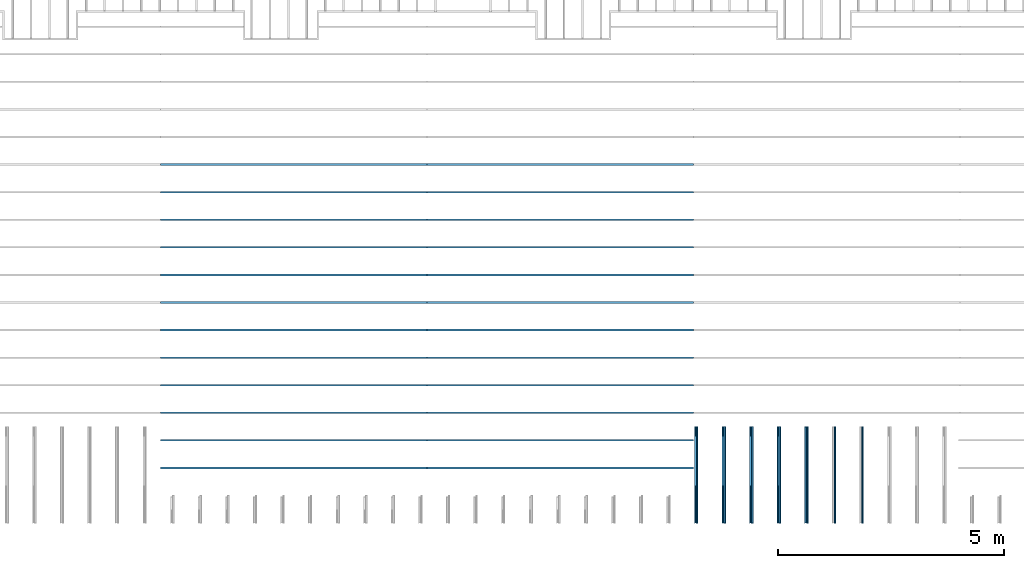
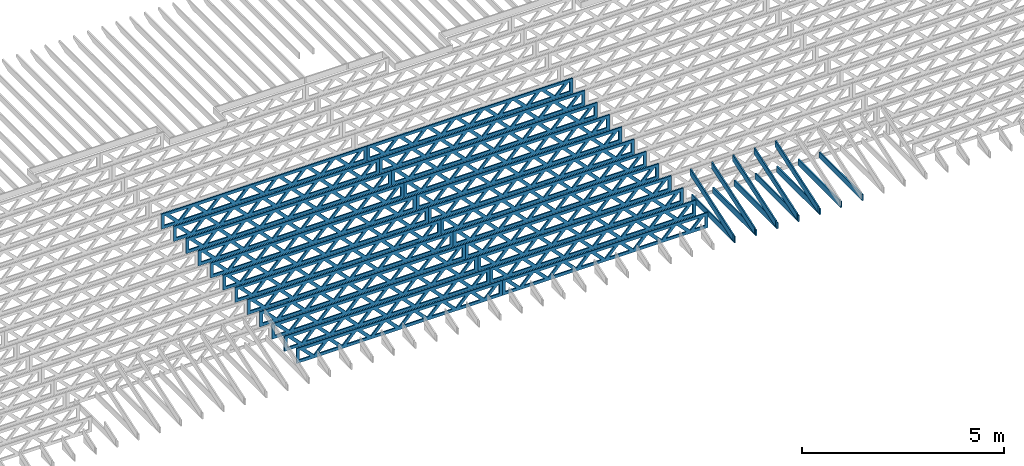
# One storey, part 7 of 17: 36 beams, 4 elements without a shape of their own.
"""IFC4 building model written with IfcOpenShell, lengths in feet."""

import ifcopenshell
import ifcopenshell.guid

model = None  # the IFC model being written
_history = None  # IfcOwnerHistory: only IFC2X3 demands one
_inside = {}  # id of a spatial element -> (the spatial element, [elements in it])
_under = {}  # id of a project, library or spatial element -> (it, [spatial elements below it])
_declared = {}  # id of a project -> (the project, [libraries it declares])
_typed = {}  # id of a type object -> (the type object, [elements of that type])
_made_of = {}  # id of a material, layer set ... -> (it, [elements and type objects made of it])


def new_model(schema):
    """Start an empty IFC model of exactly this schema.

    Asked for "IFC4X3", IfcOpenShell would pick the latest addendum, in which some entities
    have other attributes; the version numbers below select the first issue.
    IFC2X3 requires an IfcOwnerHistory on every rooted entity: one is made here for all.
    """
    global model, _history
    if schema == "IFC4X3":
        model = ifcopenshell.file(schema_version=(4, 3, 0, 0))
    else:
        model = ifcopenshell.file(schema=schema)
    _inside.clear()
    _under.clear()
    _declared.clear()
    _typed.clear()
    _made_of.clear()
    _history = None
    if model.schema == "IFC2X3":
        org = make("IfcOrganization", Name="unknown")
        user = make(
            "IfcPersonAndOrganization",
            ThePerson=make("IfcPerson", FamilyName="unknown"),
            TheOrganization=org,
        )
        app = make(
            "IfcApplication",
            ApplicationDeveloper=org,
            Version="unknown",
            ApplicationFullName="unknown",
            ApplicationIdentifier="unknown",
        )
        _history = make(
            "IfcOwnerHistory",
            OwningUser=user,
            OwningApplication=app,
            ChangeAction="ADDED",
            CreationDate=0,
        )
    return model


def make(cls, **values):
    """One entity of the class cls with the attributes given. An attribute that is None is left unset."""
    return model.create_entity(
        cls, **{name: value for name, value in values.items() if value is not None}
    )


def entity(cls, *values):
    """Any entity or typed value of the class cls, its attributes in the order of the schema. None: left unset."""
    e = model.create_entity(cls)
    for i, value in enumerate(values):
        if value is not None:
            e[i] = value
    return e


def rooted(cls, **values):
    """An entity with a GlobalId (a new one), such as an element, a storey or a relation."""
    return make(cls, GlobalId=ifcopenshell.guid.new(), OwnerHistory=_history, **values)


def si_unit(unit_type, name, prefix=None):
    """IfcSIUnit, for example si_unit("LENGTHUNIT", "METRE", prefix="MILLI")."""
    return make("IfcSIUnit", UnitType=unit_type, Prefix=prefix, Name=name)


def converted_unit(unit_type, name, factor, base, dimensions=None, offset=None):
    """IfcConversionBasedUnit, such as the inch: factor (a typed value) times the base unit."""
    return make(
        "IfcConversionBasedUnit"
        if offset is None
        else "IfcConversionBasedUnitWithOffset",
        ConversionOffset=offset,
        Dimensions=None
        if dimensions is None
        else entity("IfcDimensionalExponents", *dimensions),
        UnitType=unit_type,
        Name=name,
        ConversionFactor=make(
            "IfcMeasureWithUnit", ValueComponent=factor, UnitComponent=base
        ),
    )


def derived_unit(unit_type, elements):
    """IfcDerivedUnit: a product of units, each with its exponent."""
    return make(
        "IfcDerivedUnit",
        Elements=[
            make("IfcDerivedUnitElement", Unit=unit, Exponent=power)
            for unit, power in elements
        ],
        UnitType=unit_type,
    )


def assignment(units):
    """IfcUnitAssignment: the units of a project."""
    return None if units is None else make("IfcUnitAssignment", Units=units)


def point(xyz):
    """IfcCartesianPoint."""
    return None if xyz is None else make("IfcCartesianPoint", Coordinates=xyz)


def direction(xyz):
    """IfcDirection."""
    return None if xyz is None else make("IfcDirection", DirectionRatios=xyz)


def frame(location, z_axis=None, x_axis=None):
    """IfcAxis2Placement3D, a coordinate frame: its origin and axes. An axis left out is left unset."""
    return make(
        "IfcAxis2Placement3D",
        Location=point(location),
        Axis=direction(z_axis),
        RefDirection=direction(x_axis),
    )


def frame_2d(location, x_axis=None):
    """IfcAxis2Placement2D, a coordinate frame in the plane: its origin and x axis."""
    return make(
        "IfcAxis2Placement2D", Location=point(location), RefDirection=direction(x_axis)
    )


def origin():
    """The frame at (0, 0, 0) with its axes left unset."""
    return frame((0.0, 0.0, 0.0))


def origin_2d_with_axis():
    """The frame at (0, 0) in the plane with the x axis (1, 0) written out."""
    return frame_2d((0.0, 0.0), x_axis=(1.0, 0.0))


def place(relative_to, where):
    """IfcLocalPlacement: puts the frame where relative to a parent placement (None: the world)."""
    return make(
        "IfcLocalPlacement", PlacementRelTo=relative_to, RelativePlacement=where
    )


def context(
    kind, dimensions, precision=None, world=None, true_north=None, identifier=None
):
    """IfcGeometricRepresentationContext, for example the 3D "Model" context."""
    return make(
        "IfcGeometricRepresentationContext",
        ContextIdentifier=identifier,
        ContextType=kind,
        CoordinateSpaceDimension=dimensions,
        Precision=precision,
        WorldCoordinateSystem=world,
        TrueNorth=true_north,
    )


def subcontext(parent, identifier, kind, view, scale=None):
    """IfcGeometricRepresentationSubContext, for example "Body" below "Model"."""
    return make(
        "IfcGeometricRepresentationSubContext",
        ContextIdentifier=identifier,
        ContextType=kind,
        ParentContext=parent,
        TargetScale=scale,
        TargetView=view,
    )


def project(units=None, contexts=None):
    """IfcProject with its units and contexts."""
    return rooted(
        "IfcProject",
        Name="project",
        RepresentationContexts=contexts,
        UnitsInContext=assignment(units),
    )


def spatial(cls, under=None, at=None, **own):
    """A site, building, storey or space (cls), placed at a placement, below another one or the project."""
    s = rooted(cls, ObjectPlacement=at, **own)
    if under is not None:
        _under.setdefault(under.id(), (under, []))[1].append(s)
    return s


def profile(cls, at=None, kind="AREA", **sizes):
    """A parametric profile (cls). Its sizes go by their IFC names, for example OverallWidth=200.0."""
    return make(cls, ProfileType=kind, Position=at, **sizes)


def rectangle(**sizes):
    """IfcRectangleProfileDef."""
    return profile("IfcRectangleProfileDef", **sizes)


def extrude(swept, where, along, depth):
    """IfcExtrudedAreaSolid: the profile swept, set in the frame where, extruded along a direction by depth."""
    return make(
        "IfcExtrudedAreaSolid",
        SweptArea=swept,
        Position=where,
        ExtrudedDirection=direction(along),
        Depth=depth,
    )


def clip(a, b, op="DIFFERENCE"):
    """IfcBooleanClippingResult: the solid a cut by the half space b."""
    return make(
        "IfcBooleanClippingResult", Operator=op, FirstOperand=a, SecondOperand=b
    )


def halfspace(plane, agree):
    """IfcHalfSpaceSolid: all space on one side of the plane z = 0 of the frame plane."""
    return make(
        "IfcHalfSpaceSolid",
        BaseSurface=make("IfcPlane", Position=plane),
        AgreementFlag=agree,
    )


def shape(context_of_items, identifier, shape_type, items):
    """IfcShapeRepresentation: the items that make up one representation, for example the "Body"."""
    return make(
        "IfcShapeRepresentation",
        ContextOfItems=context_of_items,
        RepresentationIdentifier=identifier,
        RepresentationType=shape_type,
        Items=items,
    )


def source(mapping_origin, context_of_items, identifier, shape_type, items):
    """IfcRepresentationMap: a shape defined once, which mapped items show again and again."""
    return make(
        "IfcRepresentationMap",
        MappingOrigin=mapping_origin,
        MappedRepresentation=shape(context_of_items, identifier, shape_type, items),
    )


def transform(
    local_origin,
    x_axis=None,
    y_axis=None,
    z_axis=None,
    scale=None,
    scale2=None,
    scale3=None,
    uniform=True,
):
    """IfcCartesianTransformationOperator3D, or its non-uniform kind. x_axis, y_axis, z_axis: its Axis1, 2, 3."""
    if uniform:
        return make(
            "IfcCartesianTransformationOperator3D",
            Axis1=direction(x_axis),
            Axis2=direction(y_axis),
            LocalOrigin=point(local_origin),
            Scale=scale,
            Axis3=direction(z_axis),
        )
    return make(
        "IfcCartesianTransformationOperator3DnonUniform",
        Axis1=direction(x_axis),
        Axis2=direction(y_axis),
        LocalOrigin=point(local_origin),
        Scale=scale,
        Axis3=direction(z_axis),
        Scale2=scale2,
        Scale3=scale3,
    )


def mapped(mapping_source, mapping_target):
    """IfcMappedItem: shows the shape of a source again, moved by a transform."""
    return make(
        "IfcMappedItem", MappingSource=mapping_source, MappingTarget=mapping_target
    )


def material(Name=None, Category=None):
    """IfcMaterial."""
    return make("IfcMaterial", Name=Name, Category=Category)


def material_profile(
    of_material, cross_section, Name=None, Category=None, Priority=None
):
    """IfcMaterialProfile: a cross section and its material."""
    return make(
        "IfcMaterialProfile",
        Name=Name,
        Material=of_material,
        Profile=cross_section,
        Priority=Priority,
        Category=Category,
    )


def profile_set(profiles, Name=None, composite=None):
    """IfcMaterialProfileSet."""
    return make(
        "IfcMaterialProfileSet",
        Name=Name,
        MaterialProfiles=profiles,
        CompositeProfile=composite,
    )


def profile_usage(for_profile_set, cardinal=None, extent=None):
    """IfcMaterialProfileSetUsage: how a profile set lies along its element."""
    return make(
        "IfcMaterialProfileSetUsage",
        ForProfileSet=for_profile_set,
        CardinalPoint=cardinal,
        ReferenceExtent=extent,
    )


def made_of(thing, what):
    """Note that an element or type object is made of a material, layer set ...; save() writes the relation."""
    if what is not None:
        _made_of.setdefault(what.id(), (what, []))[1].append(thing)
    return thing


def type_object(cls, material=None, **own):
    """A type object (cls), such as IfcWallType, which elements share."""
    return made_of(rooted(cls, **own), material)


def type_shapes(of_type, sources):
    """Give a type object the sources (RepresentationMaps) that its elements show as mapped items."""
    of_type.RepresentationMaps = sources


def element(
    cls,
    number,
    at=None,
    inside=None,
    cuts=None,
    type_object=None,
    material=None,
    context=None,
    identifier="Body",
    shape_type=None,
    held_by="IfcProductDefinitionShape",
    body=None,
    shapes=None,
    **own,
):
    """One element of the class cls, such as IfcWall. Its Tag is "e" and its number.

    at: its placement. inside: the storey or other place that contains it. cuts: it is an
    opening in that element (IfcRelVoidsElement). A single representation is given by context,
    identifier, shape_type and body (its items); several are given by shapes. held_by: the class
    of the entity that holds the representations. save() writes the other relations.
    """
    e = rooted(cls, Tag="e%d" % number, ObjectPlacement=at, **own)
    if body is not None:
        shapes = [shape(context, identifier, shape_type, body)]
    if shapes is not None:
        e.Representation = make(held_by, Representations=shapes)
    if inside is not None:
        _inside.setdefault(inside.id(), (inside, []))[1].append(e)
    if cuts is not None:
        rooted(
            "IfcRelVoidsElement", RelatingBuildingElement=cuts, RelatedOpeningElement=e
        )
    if type_object is not None:
        _typed.setdefault(type_object.id(), (type_object, []))[1].append(e)
    return made_of(e, material)


def aggregate(whole, parts):
    """IfcRelAggregates: a whole, such as a stair, and the parts it consists of."""
    return rooted("IfcRelAggregates", RelatingObject=whole, RelatedObjects=parts)


def save(model, path):
    """Write the relations noted so far, then the file.

    IfcRelAggregates (storeys below a building ...), IfcRelContainedInSpatialStructure (elements
    in a storey), IfcRelDefinesByType, IfcRelAssociatesMaterial and IfcRelDeclares: one each for
    every whole, place, type object, material and project.
    """
    for whole, parts in _under.values():
        aggregate(whole, parts)
    for where, things in _inside.values():
        rooted(
            "IfcRelContainedInSpatialStructure",
            RelatedElements=things,
            RelatingStructure=where,
        )
    for kind, things in _typed.values():
        rooted("IfcRelDefinesByType", RelatedObjects=things, RelatingType=kind)
    for what, things in _made_of.values():
        rooted("IfcRelAssociatesMaterial", RelatedObjects=things, RelatingMaterial=what)
    for by, libraries in _declared.values():
        rooted("IfcRelDeclares", RelatingContext=by, RelatedDefinitions=libraries)
    model.write(path)


model = new_model("IFC4")

# Units and contexts
model_context = context("Model", 3, precision=0.0001, world=origin(), true_north=direction((6.12303176911189e-17, 1.0)))
body_context = subcontext(model_context, "Body", "Model", "MODEL_VIEW")
ifc_project = project(units=[converted_unit("LENGTHUNIT", "FOOT", entity("IfcRatioMeasure", 0.3048), si_unit("LENGTHUNIT", "METRE"), dimensions=[1, 0, 0, 0, 0, 0, 0]), converted_unit("AREAUNIT", "SQUARE FOOT", entity("IfcRatioMeasure", 0.09290304), si_unit("AREAUNIT", "SQUARE_METRE"), dimensions=[2, 0, 0, 0, 0, 0, 0]), converted_unit("VOLUMEUNIT", "CUBIC FOOT", entity("IfcRatioMeasure", 0.028316846592), si_unit("VOLUMEUNIT", "CUBIC_METRE"), dimensions=[3, 0, 0, 0, 0, 0, 0]), converted_unit("PLANEANGLEUNIT", "DEGREE", entity("IfcRatioMeasure", 0.0174532925199433), si_unit("PLANEANGLEUNIT", "RADIAN"), dimensions=[0, 0, 0, 0, 0, 0, 0]), si_unit("MASSUNIT", "GRAM", prefix="KILO"), derived_unit("MASSDENSITYUNIT", [(si_unit("MASSUNIT", "GRAM", prefix="KILO"), 1), (si_unit("LENGTHUNIT", "METRE"), -3)]), derived_unit("MOMENTOFINERTIAUNIT", [(si_unit("LENGTHUNIT", "METRE"), 4)]), si_unit("TIMEUNIT", "SECOND"), si_unit("FREQUENCYUNIT", "HERTZ"), si_unit("THERMODYNAMICTEMPERATUREUNIT", "DEGREE_CELSIUS"), derived_unit("THERMALTRANSMITTANCEUNIT", [(si_unit("MASSUNIT", "GRAM", prefix="KILO"), 1), (si_unit("THERMODYNAMICTEMPERATUREUNIT", "KELVIN"), -1), (si_unit("TIMEUNIT", "SECOND"), -3)]), derived_unit("VOLUMETRICFLOWRATEUNIT", [(si_unit("LENGTHUNIT", "METRE"), 3), (si_unit("TIMEUNIT", "SECOND"), -1)]), si_unit("ELECTRICCURRENTUNIT", "AMPERE"), si_unit("ELECTRICVOLTAGEUNIT", "VOLT"), si_unit("POWERUNIT", "WATT"), si_unit("FORCEUNIT", "NEWTON"), si_unit("ILLUMINANCEUNIT", "LUX"), si_unit("LUMINOUSFLUXUNIT", "LUMEN"), si_unit("LUMINOUSINTENSITYUNIT", "CANDELA"), derived_unit("USERDEFINED", [(si_unit("MASSUNIT", "GRAM", prefix="KILO"), -1), (si_unit("LENGTHUNIT", "METRE"), -2), (si_unit("TIMEUNIT", "SECOND"), 3), (si_unit("LUMINOUSFLUXUNIT", "LUMEN"), 1)]), derived_unit("LINEARVELOCITYUNIT", [(si_unit("LENGTHUNIT", "METRE"), 1), (si_unit("TIMEUNIT", "SECOND"), -1)]), si_unit("PRESSUREUNIT", "PASCAL"), derived_unit("USERDEFINED", [(si_unit("LENGTHUNIT", "METRE"), -2), (si_unit("MASSUNIT", "GRAM", prefix="KILO"), 1), (si_unit("TIMEUNIT", "SECOND"), -2)]), derived_unit("LINEARFORCEUNIT", [(si_unit("MASSUNIT", "GRAM", prefix="KILO"), 1), (si_unit("LENGTHUNIT", "METRE"), 1), (si_unit("TIMEUNIT", "SECOND"), -2), (si_unit("LENGTHUNIT", "METRE"), -1)]), derived_unit("PLANARFORCEUNIT", [(si_unit("MASSUNIT", "GRAM", prefix="KILO"), 1), (si_unit("LENGTHUNIT", "METRE"), 1), (si_unit("TIMEUNIT", "SECOND"), -2), (si_unit("LENGTHUNIT", "METRE"), -2)])], contexts=[model_context])

# Site, building, storey
site_placement = place(None, origin())
site = spatial("IfcSite", under=ifc_project, at=site_placement, CompositionType="ELEMENT")
building_placement = place(site_placement, origin())
building = spatial("IfcBuilding", under=site, at=building_placement, CompositionType="ELEMENT")
storey_placement = place(building_placement, frame((0.0, 0.0, 30.4375000000082)))
storey = spatial("IfcBuildingStorey", under=building, at=storey_placement, Name="ROOF", CompositionType="ELEMENT", Elevation=30.4375000000082)

# Assembly, beams
assembly_1_placement = place(storey_placement, origin())
assembly_1 = element("IfcElementAssembly", 1, at=assembly_1_placement, inside=storey, Name="Structural Beam System:Structural Framing System", ObjectType="Structural Beam System:Structural Framing System", AssemblyPlace="NOTDEFINED", PredefinedType="BEAM_GRID")
ifc_material_1 = material(Name="WOOD TRUSS", Category="Materials")
ifc_material_profile_1 = material_profile(ifc_material_1, rectangle(XDim=1.73473973950632, YDim=0.125, at=origin_2d_with_axis()))
ifc_material_profile_2 = material_profile(ifc_material_1, rectangle(XDim=1.73473973950633, YDim=0.125, at=frame_2d((-1.11022302462516e-16, 0.0), x_axis=(1.0, 0.0))))
ifc_material_profile_3 = material_profile(ifc_material_1, rectangle(XDim=1.73473973950632, YDim=0.125, at=origin_2d_with_axis()))
ifc_material_profile_4 = material_profile(ifc_material_1, rectangle(XDim=1.73473973950633, YDim=0.125, at=origin_2d_with_axis()))
ifc_material_profile_5 = material_profile(ifc_material_1, rectangle(XDim=1.73473973950632, YDim=0.125, at=frame_2d((-5.55111512312578e-17, 0.0), x_axis=(1.0, 0.0))))
ifc_material_profile_6 = material_profile(ifc_material_1, rectangle(XDim=1.73473973950633, YDim=0.125, at=frame_2d((-2.77555756156289e-16, 0.0), x_axis=(1.0, 0.0))))
ifc_material_profile_7 = material_profile(ifc_material_1, rectangle(XDim=1.73473973950632, YDim=0.125, at=frame_2d((-4.9960036108132e-16, 0.0), x_axis=(1.0, 0.0))))
ifc_material_profile_8 = material_profile(ifc_material_1, rectangle(XDim=1.73473973950633, YDim=0.125, at=frame_2d((4.44089209850063e-16, 0.0), x_axis=(1.0, 0.0))))
ifc_material_profile_9 = material_profile(ifc_material_1, rectangle(XDim=1.73473973950632, YDim=0.125, at=origin_2d_with_axis()))
ifc_material_profile_10 = material_profile(ifc_material_1, rectangle(XDim=1.73473973950633, YDim=0.125, at=frame_2d((-4.9960036108132e-16, 0.0), x_axis=(1.0, 0.0))))
ifc_material_profile_11 = material_profile(ifc_material_1, rectangle(XDim=0.291666666666664, YDim=0.125, at=frame_2d((-2.77555756156289e-17, 0.0), x_axis=(1.0, 0.0))))
ifc_material_profile_12 = material_profile(ifc_material_1, rectangle(XDim=0.291666666666628, YDim=0.124999999999995, at=frame_2d((-5.55111512312578e-17, 0.0), x_axis=(1.0, 0.0))))
ifc_material_profile_13 = material_profile(ifc_material_1, rectangle(XDim=0.916666666666666, YDim=0.125000000000003, at=frame_2d((-2.77555756156289e-17, 0.0), x_axis=(1.0, 0.0))))
ifc_material_profile_14 = material_profile(ifc_material_1, rectangle(XDim=0.916666666666651, YDim=0.125, at=frame_2d((-2.77555756156289e-17, 0.0), x_axis=(1.0, 0.0))))
ifc_profile_set_1 = profile_set([ifc_material_profile_1, ifc_material_profile_2, ifc_material_profile_3, ifc_material_profile_4, ifc_material_profile_5, ifc_material_profile_6, ifc_material_profile_7, ifc_material_profile_8, ifc_material_profile_9, ifc_material_profile_10, ifc_material_profile_11, ifc_material_profile_12, ifc_material_profile_13, ifc_material_profile_14])
ifc_profile_usage_1 = profile_usage(ifc_profile_set_1, cardinal=8)
beam_type_1 = type_object("IfcBeamType", PredefinedType="BEAM", material=ifc_profile_set_1)
shared_shape_1 = source(origin(), body_context, "Body", "SweptSolid", [
    extrude(rectangle(XDim=1.73473973950632, YDim=0.125, at=frame_2d((-5.55111512312578e-16, 0.0), x_axis=(1.0, 0.0))), frame((5.85339326404794, 0.0, 0.101118361020562), z_axis=(0.720569184836762, 0.0, -0.693383046997606), x_axis=(0.693383046997606, 0.0, 0.720569184836762)), (0.0, 0.0, 1.0), 0.291666666666667),
    extrude(rectangle(XDim=1.73473973950633, YDim=0.125, at=frame_2d((-4.9960036108132e-16, 0.0), x_axis=(1.0, 0.0))), frame((4.60310739037467, 0.0, -0.101118361020407), z_axis=(0.720569184836758, 0.0, 0.69338304699761), x_axis=(0.69338304699761, 0.0, -0.720569184836758)), (0.0, 0.0, 1.0), 0.291666666666667),
    extrude(rectangle(XDim=1.73473973950632, YDim=0.125, at=frame_2d((3.33066907387547e-16, 0.0), x_axis=(1.0, 0.0))), frame((3.18672659738144, 0.0, 0.101118361020562), z_axis=(0.720569184836762, 0.0, -0.693383046997606), x_axis=(0.693383046997606, 0.0, 0.720569184836762)), (0.0, 0.0, 1.0), 0.291666666666667),
    extrude(rectangle(XDim=1.73473973950633, YDim=0.125, at=frame_2d((-1.11022302462516e-16, 0.0), x_axis=(1.0, 0.0))), frame((1.93644072370817, 0.0, -0.101118361020407), z_axis=(0.720569184836758, 0.0, 0.69338304699761), x_axis=(0.69338304699761, 0.0, -0.720569184836758)), (0.0, 0.0, 1.0), 0.291666666666666),
    extrude(rectangle(XDim=1.73473973950632, YDim=0.125, at=frame_2d((5.55111512312578e-17, 0.0), x_axis=(1.0, 0.0))), frame((0.520059930714937, 0.0, 0.101118361020562), z_axis=(0.720569184836762, 0.0, -0.693383046997606), x_axis=(0.693383046997606, 0.0, 0.720569184836762)), (0.0, 0.0, 1.0), 0.291666666666667),
    extrude(rectangle(XDim=1.73473973950633, YDim=0.125, at=origin_2d_with_axis()), frame((-0.730225942958334, 0.0, -0.101118361020407), z_axis=(0.720569184836758, 0.0, 0.69338304699761), x_axis=(0.69338304699761, 0.0, -0.720569184836758)), (0.0, 0.0, 1.0), 0.291666666666666),
    extrude(rectangle(XDim=1.73473973950632, YDim=0.125, at=frame_2d((-5.55111512312578e-17, 0.0), x_axis=(1.0, 0.0))), frame((-2.14660673595157, 0.0, 0.101118361020562), z_axis=(0.720569184836762, 0.0, -0.693383046997606), x_axis=(0.693383046997606, 0.0, 0.720569184836762)), (0.0, 0.0, 1.0), 0.291666666666667),
    extrude(rectangle(XDim=1.73473973950633, YDim=0.125, at=frame_2d((-2.77555756156289e-16, 0.0), x_axis=(1.0, 0.0))), frame((-3.39689260962484, 0.0, -0.101118361020407), z_axis=(0.720569184836758, 0.0, 0.69338304699761), x_axis=(0.69338304699761, 0.0, -0.720569184836758)), (0.0, 0.0, 1.0), 0.291666666666666),
    extrude(rectangle(XDim=1.73473973950632, YDim=0.125, at=origin_2d_with_axis()), frame((-4.81327340261807, 0.0, 0.101118361020562), z_axis=(0.720569184836762, 0.0, -0.693383046997606), x_axis=(0.693383046997606, 0.0, 0.720569184836762)), (0.0, 0.0, 1.0), 0.291666666666667),
    extrude(rectangle(XDim=1.73473973950633, YDim=0.125, at=frame_2d((-4.9960036108132e-16, 0.0), x_axis=(1.0, 0.0))), frame((-6.06355927629134, 0.0, -0.101118361020407), z_axis=(0.720569184836758, 0.0, 0.69338304699761), x_axis=(0.69338304699761, 0.0, -0.720569184836758)), (0.0, 0.0, 1.0), 0.291666666666667),
    extrude(rectangle(XDim=1.73473973950632, YDim=0.125, at=frame_2d((-1.0547118733939e-15, 0.0), x_axis=(1.0, 0.0))), frame((8.52005993071445, 0.0, 0.101118361020506), z_axis=(0.720569184836761, 0.0, -0.693383046997607), x_axis=(0.693383046997607, 0.0, 0.720569184836761)), (0.0, 0.0, 1.0), 0.291666666666667),
    extrude(rectangle(XDim=1.73473973950633, YDim=0.125, at=origin_2d_with_axis()), frame((7.26977405704118, 0.0, -0.101118361020463), z_axis=(0.720569184836758, 0.0, 0.69338304699761), x_axis=(0.69338304699761, 0.0, -0.720569184836758)), (0.0, 0.0, 1.0), 0.291666666666667),
    extrude(rectangle(XDim=1.73473973950632, YDim=0.125, at=frame_2d((4.44089209850063e-16, 0.0), x_axis=(1.0, 0.0))), frame((-7.47994006928457, 0.0, 0.101118361020561), z_axis=(0.720569184836762, 0.0, -0.693383046997606), x_axis=(0.693383046997606, 0.0, 0.720569184836762)), (0.0, 0.0, 1.0), 0.291666666666666),
    extrude(rectangle(XDim=1.73473973950633, YDim=0.125, at=origin_2d_with_axis()), frame((-8.73022594295784, 0.0, -0.101118361020408), z_axis=(0.720569184836758, 0.0, 0.69338304699761), x_axis=(0.69338304699761, 0.0, -0.720569184836758)), (0.0, 0.0, 1.0), 0.291666666666666),
    extrude(rectangle(XDim=0.291666666666664, YDim=0.125, at=frame_2d((-2.77555756156289e-17, 0.0), x_axis=(1.0, 0.0))), frame((-9.66666666666609, 0.0, 0.604166666666611), z_axis=(1.0, 0.0, 0.0), x_axis=(0.0, 0.0, -1.0)), (0.0, 0.0, 1.0), 19.3333333333322),
    extrude(rectangle(XDim=0.291666666666628, YDim=0.124999999999995, at=frame_2d((-5.55111512312578e-17, 0.0), x_axis=(1.0, 0.0))), frame((-9.66666666666588, 0.0, -0.604166666666693), z_axis=(1.0, 0.0, 0.0), x_axis=(0.0, 0.0, -1.0)), (0.0, 0.0, 1.0), 19.333333333332),
    extrude(rectangle(XDim=0.916666666666666, YDim=0.125000000000003, at=frame_2d((-2.77555756156289e-17, 0.0), x_axis=(1.0, 0.0))), frame((9.3749999999994, 0.0, 0.0), z_axis=(1.0, 0.0, 0.0), x_axis=(0.0, 0.0, -1.0)), (0.0, 0.0, 1.0), 0.291666666666687),
    extrude(rectangle(XDim=0.916666666666651, YDim=0.125, at=frame_2d((-2.77555756156289e-17, 0.0), x_axis=(1.0, 0.0))), frame((-9.66666666666609, 0.0, 0.0), z_axis=(1.0, 0.0, 0.0), x_axis=(0.0, 0.0, -1.0)), (0.0, 0.0, 1.0), 0.291666666666687),
])
type_shapes(beam_type_1, [shared_shape_1])
beam_1_placement = place(assembly_1_placement, frame((-193.404827152229, 947.861934882651, 0.749999999991623)))
beam_1 = element("IfcBeam", 2, at=beam_1_placement, type_object=beam_type_1, material=ifc_profile_usage_1, PredefinedType="BEAM", context=body_context, shape_type="MappedRepresentation", body=[
    mapped(shared_shape_1, transform((0.0, 0.0, 0.0), scale=1.0)),
])
ifc_profile_usage_2 = profile_usage(ifc_profile_set_1, cardinal=8)
beam_2_placement = place(assembly_1_placement, frame((-193.404827152229, 945.861934882651, 0.74999999999163)))
beam_2 = element("IfcBeam", 3, at=beam_2_placement, type_object=beam_type_1, material=ifc_profile_usage_2, PredefinedType="BEAM", context=body_context, shape_type="MappedRepresentation", body=[
    mapped(shared_shape_1, transform((0.0, 0.0, 0.0), scale=1.0)),
])
ifc_profile_usage_3 = profile_usage(ifc_profile_set_1, cardinal=8)
beam_3_placement = place(assembly_1_placement, frame((-193.404827152229, 943.861934882651, 0.74999999999163)))
beam_3 = element("IfcBeam", 4, at=beam_3_placement, type_object=beam_type_1, material=ifc_profile_usage_3, PredefinedType="BEAM", context=body_context, shape_type="MappedRepresentation", body=[
    mapped(shared_shape_1, transform((0.0, 0.0, 0.0), scale=1.0)),
])
ifc_profile_usage_4 = profile_usage(ifc_profile_set_1, cardinal=8)
beam_4_placement = place(assembly_1_placement, frame((-193.404827152229, 941.861934882651, 0.749999999991637)))
beam_4 = element("IfcBeam", 5, at=beam_4_placement, type_object=beam_type_1, material=ifc_profile_usage_4, PredefinedType="BEAM", context=body_context, shape_type="MappedRepresentation", body=[
    mapped(shared_shape_1, transform((0.0, 0.0, 0.0), scale=1.0)),
])
ifc_profile_usage_5 = profile_usage(ifc_profile_set_1, cardinal=8)
beam_5_placement = place(assembly_1_placement, frame((-193.404827152229, 939.861934882651, 0.749999999991644)))
beam_5 = element("IfcBeam", 6, at=beam_5_placement, type_object=beam_type_1, material=ifc_profile_usage_5, PredefinedType="BEAM", context=body_context, shape_type="MappedRepresentation", body=[
    mapped(shared_shape_1, transform((0.0, 0.0, 0.0), scale=1.0)),
])
ifc_profile_usage_6 = profile_usage(ifc_profile_set_1, cardinal=8)
beam_6_placement = place(assembly_1_placement, frame((-193.404827152229, 937.861934882651, 0.749999999991651)))
beam_6 = element("IfcBeam", 7, at=beam_6_placement, type_object=beam_type_1, material=ifc_profile_usage_6, PredefinedType="BEAM", context=body_context, shape_type="MappedRepresentation", body=[
    mapped(shared_shape_1, transform((0.0, 0.0, 0.0), scale=1.0)),
])
ifc_profile_usage_7 = profile_usage(ifc_profile_set_1, cardinal=8)
beam_7_placement = place(assembly_1_placement, frame((-193.404827152229, 935.861934882651, 0.749999999991651)))
beam_7 = element("IfcBeam", 8, at=beam_7_placement, type_object=beam_type_1, material=ifc_profile_usage_7, PredefinedType="BEAM", context=body_context, shape_type="MappedRepresentation", body=[
    mapped(shared_shape_1, transform((0.0, 0.0, 0.0), scale=1.0)),
])
ifc_profile_usage_8 = profile_usage(ifc_profile_set_1, cardinal=8)
beam_8_placement = place(assembly_1_placement, frame((-193.404827152229, 933.861934882651, 0.749999999991658)))
beam_8 = element("IfcBeam", 9, at=beam_8_placement, type_object=beam_type_1, material=ifc_profile_usage_8, PredefinedType="BEAM", context=body_context, shape_type="MappedRepresentation", body=[
    mapped(shared_shape_1, transform((0.0, 0.0, 0.0), scale=1.0)),
])
ifc_profile_usage_9 = profile_usage(ifc_profile_set_1, cardinal=8)
beam_9_placement = place(assembly_1_placement, frame((-193.404827152229, 931.861934882651, 0.749999999991665)))
beam_9 = element("IfcBeam", 10, at=beam_9_placement, type_object=beam_type_1, material=ifc_profile_usage_9, PredefinedType="BEAM", context=body_context, shape_type="MappedRepresentation", body=[
    mapped(shared_shape_1, transform((0.0, 0.0, 0.0), scale=1.0)),
])
ifc_profile_usage_10 = profile_usage(ifc_profile_set_1, cardinal=8)
beam_10_placement = place(assembly_1_placement, frame((-193.404827152229, 929.861934882651, 0.749999999991672)))
beam_10 = element("IfcBeam", 11, at=beam_10_placement, type_object=beam_type_1, material=ifc_profile_usage_10, PredefinedType="BEAM", context=body_context, shape_type="MappedRepresentation", body=[
    mapped(shared_shape_1, transform((0.0, 0.0, 0.0), scale=1.0)),
])
ifc_profile_usage_11 = profile_usage(ifc_profile_set_1, cardinal=8)
beam_11_placement = place(assembly_1_placement, frame((-193.404827152229, 927.861934882651, 0.74999999999168)))
beam_11 = element("IfcBeam", 12, at=beam_11_placement, type_object=beam_type_1, material=ifc_profile_usage_11, PredefinedType="BEAM", context=body_context, shape_type="MappedRepresentation", body=[
    mapped(shared_shape_1, transform((0.0, 0.0, 0.0), scale=1.0)),
])
ifc_profile_usage_12 = profile_usage(ifc_profile_set_1, cardinal=8)
beam_12_placement = place(assembly_1_placement, frame((-193.404827152229, 925.861934882651, 0.74999999999168)))
beam_12 = element("IfcBeam", 13, at=beam_12_placement, type_object=beam_type_1, material=ifc_profile_usage_12, PredefinedType="BEAM", context=body_context, shape_type="MappedRepresentation", body=[
    mapped(shared_shape_1, transform((0.0, 0.0, 0.0), scale=1.0)),
])
aggregate(assembly_1, [beam_1, beam_2, beam_3, beam_4, beam_5, beam_6, beam_7, beam_8, beam_9, beam_10, beam_11, beam_12])

assembly_2_placement = place(storey_placement, origin())
assembly_2 = element("IfcElementAssembly", 14, at=assembly_2_placement, inside=storey, Name="Structural Beam System:Structural Framing System", ObjectType="Structural Beam System:Structural Framing System", AssemblyPlace="NOTDEFINED", PredefinedType="BEAM_GRID")
ifc_profile_usage_13 = profile_usage(ifc_profile_set_1, cardinal=8)
beam_13_placement = place(assembly_2_placement, frame((-212.738160485494, 947.861934882651, 0.749999999991623), z_axis=(0.0, 0.0, 1.0), x_axis=(-1.0, 0.0, 0.0)))
beam_13 = element("IfcBeam", 15, at=beam_13_placement, type_object=beam_type_1, material=ifc_profile_usage_13, PredefinedType="BEAM", context=body_context, shape_type="MappedRepresentation", body=[
    mapped(shared_shape_1, transform((0.0, 0.0, 0.0), scale=1.0)),
])
ifc_profile_usage_14 = profile_usage(ifc_profile_set_1, cardinal=8)
beam_14_placement = place(assembly_2_placement, frame((-212.738160485494, 945.861934882651, 0.74999999999163), z_axis=(0.0, 0.0, 1.0), x_axis=(-1.0, 0.0, 0.0)))
beam_14 = element("IfcBeam", 16, at=beam_14_placement, type_object=beam_type_1, material=ifc_profile_usage_14, PredefinedType="BEAM", context=body_context, shape_type="MappedRepresentation", body=[
    mapped(shared_shape_1, transform((0.0, 0.0, 0.0), scale=1.0)),
])
ifc_profile_usage_15 = profile_usage(ifc_profile_set_1, cardinal=8)
beam_15_placement = place(assembly_2_placement, frame((-212.738160485494, 943.861934882651, 0.74999999999163), z_axis=(0.0, 0.0, 1.0), x_axis=(-1.0, 0.0, 0.0)))
beam_15 = element("IfcBeam", 17, at=beam_15_placement, type_object=beam_type_1, material=ifc_profile_usage_15, PredefinedType="BEAM", context=body_context, shape_type="MappedRepresentation", body=[
    mapped(shared_shape_1, transform((0.0, 0.0, 0.0), scale=1.0)),
])
ifc_profile_usage_16 = profile_usage(ifc_profile_set_1, cardinal=8)
beam_16_placement = place(assembly_2_placement, frame((-212.738160485494, 941.861934882651, 0.749999999991637), z_axis=(0.0, 0.0, 1.0), x_axis=(-1.0, 0.0, 0.0)))
beam_16 = element("IfcBeam", 18, at=beam_16_placement, type_object=beam_type_1, material=ifc_profile_usage_16, PredefinedType="BEAM", context=body_context, shape_type="MappedRepresentation", body=[
    mapped(shared_shape_1, transform((0.0, 0.0, 0.0), scale=1.0)),
])
ifc_profile_usage_17 = profile_usage(ifc_profile_set_1, cardinal=8)
beam_17_placement = place(assembly_2_placement, frame((-212.738160485494, 939.861934882651, 0.749999999991644), z_axis=(0.0, 0.0, 1.0), x_axis=(-1.0, 0.0, 0.0)))
beam_17 = element("IfcBeam", 19, at=beam_17_placement, type_object=beam_type_1, material=ifc_profile_usage_17, PredefinedType="BEAM", context=body_context, shape_type="MappedRepresentation", body=[
    mapped(shared_shape_1, transform((0.0, 0.0, 0.0), scale=1.0)),
])
ifc_profile_usage_18 = profile_usage(ifc_profile_set_1, cardinal=8)
beam_18_placement = place(assembly_2_placement, frame((-212.738160485494, 937.861934882651, 0.749999999991651), z_axis=(0.0, 0.0, 1.0), x_axis=(-1.0, 0.0, 0.0)))
beam_18 = element("IfcBeam", 20, at=beam_18_placement, type_object=beam_type_1, material=ifc_profile_usage_18, PredefinedType="BEAM", context=body_context, shape_type="MappedRepresentation", body=[
    mapped(shared_shape_1, transform((0.0, 0.0, 0.0), scale=1.0)),
])
ifc_profile_usage_19 = profile_usage(ifc_profile_set_1, cardinal=8)
beam_19_placement = place(assembly_2_placement, frame((-212.738160485494, 935.861934882651, 0.749999999991651), z_axis=(0.0, 0.0, 1.0), x_axis=(-1.0, 0.0, 0.0)))
beam_19 = element("IfcBeam", 21, at=beam_19_placement, type_object=beam_type_1, material=ifc_profile_usage_19, PredefinedType="BEAM", context=body_context, shape_type="MappedRepresentation", body=[
    mapped(shared_shape_1, transform((0.0, 0.0, 0.0), scale=1.0)),
])
ifc_profile_usage_20 = profile_usage(ifc_profile_set_1, cardinal=8)
beam_20_placement = place(assembly_2_placement, frame((-212.738160485494, 933.861934882651, 0.749999999991658), z_axis=(0.0, 0.0, 1.0), x_axis=(-1.0, 0.0, 0.0)))
beam_20 = element("IfcBeam", 22, at=beam_20_placement, type_object=beam_type_1, material=ifc_profile_usage_20, PredefinedType="BEAM", context=body_context, shape_type="MappedRepresentation", body=[
    mapped(shared_shape_1, transform((0.0, 0.0, 0.0), scale=1.0)),
])
ifc_profile_usage_21 = profile_usage(ifc_profile_set_1, cardinal=8)
beam_21_placement = place(assembly_2_placement, frame((-212.738160485494, 931.861934882651, 0.749999999991665), z_axis=(0.0, 0.0, 1.0), x_axis=(-1.0, 0.0, 0.0)))
beam_21 = element("IfcBeam", 23, at=beam_21_placement, type_object=beam_type_1, material=ifc_profile_usage_21, PredefinedType="BEAM", context=body_context, shape_type="MappedRepresentation", body=[
    mapped(shared_shape_1, transform((0.0, 0.0, 0.0), scale=1.0)),
])
ifc_profile_usage_22 = profile_usage(ifc_profile_set_1, cardinal=8)
beam_22_placement = place(assembly_2_placement, frame((-212.738160485494, 929.861934882651, 0.749999999991672), z_axis=(0.0, 0.0, 1.0), x_axis=(-1.0, 0.0, 0.0)))
beam_22 = element("IfcBeam", 24, at=beam_22_placement, type_object=beam_type_1, material=ifc_profile_usage_22, PredefinedType="BEAM", context=body_context, shape_type="MappedRepresentation", body=[
    mapped(shared_shape_1, transform((0.0, 0.0, 0.0), scale=1.0)),
])
ifc_profile_usage_23 = profile_usage(ifc_profile_set_1, cardinal=8)
beam_23_placement = place(assembly_2_placement, frame((-212.738160485494, 927.861934882651, 0.74999999999168), z_axis=(0.0, 0.0, 1.0), x_axis=(-1.0, 0.0, 0.0)))
beam_23 = element("IfcBeam", 25, at=beam_23_placement, type_object=beam_type_1, material=ifc_profile_usage_23, PredefinedType="BEAM", context=body_context, shape_type="MappedRepresentation", body=[
    mapped(shared_shape_1, transform((0.0, 0.0, 0.0), scale=1.0)),
])
ifc_profile_usage_24 = profile_usage(ifc_profile_set_1, cardinal=8)
beam_24_placement = place(assembly_2_placement, frame((-212.738160485494, 925.861934882651, 0.74999999999168), z_axis=(0.0, 0.0, 1.0), x_axis=(-1.0, 0.0, 0.0)))
beam_24 = element("IfcBeam", 26, at=beam_24_placement, type_object=beam_type_1, material=ifc_profile_usage_24, PredefinedType="BEAM", context=body_context, shape_type="MappedRepresentation", body=[
    mapped(shared_shape_1, transform((0.0, 0.0, 0.0), scale=1.0)),
])
aggregate(assembly_2, [beam_13, beam_14, beam_15, beam_16, beam_17, beam_18, beam_19, beam_20, beam_21, beam_22, beam_23, beam_24])

assembly_3_placement = place(storey_placement, origin())
assembly_3 = element("IfcElementAssembly", 27, at=assembly_3_placement, inside=storey, Name="Structural Beam System:Structural Framing System", ObjectType="Structural Beam System:Structural Framing System", AssemblyPlace="NOTDEFINED", PredefinedType="BEAM_GRID")
ifc_material_2 = material(Name="BOTTOM CHORD OF FIELD FRAMED OVERHANG", Category="Materials")
ifc_material_profile_15 = material_profile(ifc_material_2, rectangle(XDim=0.604166666666667, YDim=0.125000000000011, at=origin_2d_with_axis()), Name="2X8 - BOTTOM CHORD")
ifc_profile_set_2 = profile_set([ifc_material_profile_15], Name="2X8 - BOTTOM CHORD")
ifc_profile_usage_25 = profile_usage(ifc_profile_set_2, cardinal=8)
beam_type_2 = type_object("IfcBeamType", Name="061100 - Wood Framing:2X8 - BOTTOM CHORD", PredefinedType="BEAM", material=ifc_profile_set_2)
shared_shape_2 = source(origin(), body_context, "Body", "SweptSolid", [
    extrude(rectangle(XDim=0.604166666666667, YDim=0.125000000000011, at=origin_2d_with_axis()), frame((-3.49999999999926, 0.0, 0.0), z_axis=(1.0, 0.0, 0.0), x_axis=(0.0, 0.0, -1.0)), (0.0, 0.0, 1.0), 6.99999999999852),
])
type_shapes(beam_type_2, [shared_shape_2])
beam_25_placement = place(assembly_3_placement, frame((-171.488158437574, 925.361942817905, 1.07291666665406), z_axis=(0.0, 0.0, 1.0), x_axis=(0.0, -1.0, 0.0)))
beam_25 = element("IfcBeam", 28, at=beam_25_placement, type_object=beam_type_2, material=ifc_profile_usage_25, Name="061100 - Wood Framing:2X8 - BOTTOM CHORD", ObjectType="061100 - Wood Framing:2X8 - BOTTOM CHORD", PredefinedType="BEAM", context=body_context, shape_type="MappedRepresentation", body=[
    mapped(shared_shape_2, transform((0.0, 0.0, 0.0), scale=1.0)),
])
ifc_profile_usage_26 = profile_usage(ifc_profile_set_2, cardinal=8)
beam_26_placement = place(assembly_3_placement, frame((-173.488158437574, 925.361942315402, 1.07291666665406), z_axis=(0.0, 0.0, 1.0), x_axis=(0.0, -1.0, 0.0)))
beam_26 = element("IfcBeam", 29, at=beam_26_placement, type_object=beam_type_2, material=ifc_profile_usage_26, Name="061100 - Wood Framing:2X8 - BOTTOM CHORD", ObjectType="061100 - Wood Framing:2X8 - BOTTOM CHORD", PredefinedType="BEAM", context=body_context, shape_type="MappedRepresentation", body=[
    mapped(shared_shape_2, transform((0.0, 0.0, 0.0), scale=1.0)),
])
ifc_profile_usage_27 = profile_usage(ifc_profile_set_2, cardinal=8)
beam_27_placement = place(assembly_3_placement, frame((-175.488158437574, 925.361941812898, 1.07291666665406), z_axis=(0.0, 0.0, 1.0), x_axis=(0.0, -1.0, 0.0)))
beam_27 = element("IfcBeam", 30, at=beam_27_placement, type_object=beam_type_2, material=ifc_profile_usage_27, Name="061100 - Wood Framing:2X8 - BOTTOM CHORD", ObjectType="061100 - Wood Framing:2X8 - BOTTOM CHORD", PredefinedType="BEAM", context=body_context, shape_type="MappedRepresentation", body=[
    mapped(shared_shape_2, transform((0.0, 0.0, 0.0), scale=1.0)),
])
ifc_profile_usage_28 = profile_usage(ifc_profile_set_2, cardinal=8)
beam_28_placement = place(assembly_3_placement, frame((-177.488158437574, 925.361941310394, 1.07291666665406), z_axis=(0.0, 0.0, 1.0), x_axis=(0.0, -1.0, 0.0)))
beam_28 = element("IfcBeam", 31, at=beam_28_placement, type_object=beam_type_2, material=ifc_profile_usage_28, Name="061100 - Wood Framing:2X8 - BOTTOM CHORD", ObjectType="061100 - Wood Framing:2X8 - BOTTOM CHORD", PredefinedType="BEAM", context=body_context, shape_type="MappedRepresentation", body=[
    mapped(shared_shape_2, transform((0.0, 0.0, 0.0), scale=1.0)),
])
ifc_profile_usage_29 = profile_usage(ifc_profile_set_2, cardinal=8)
beam_29_placement = place(assembly_3_placement, frame((-179.488158437574, 925.361940807891, 1.07291666665406), z_axis=(0.0, 0.0, 1.0), x_axis=(0.0, -1.0, 0.0)))
beam_29 = element("IfcBeam", 32, at=beam_29_placement, type_object=beam_type_2, material=ifc_profile_usage_29, Name="061100 - Wood Framing:2X8 - BOTTOM CHORD", ObjectType="061100 - Wood Framing:2X8 - BOTTOM CHORD", PredefinedType="BEAM", context=body_context, shape_type="MappedRepresentation", body=[
    mapped(shared_shape_2, transform((0.0, 0.0, 0.0), scale=1.0)),
])
ifc_profile_usage_30 = profile_usage(ifc_profile_set_2, cardinal=8)
beam_30_placement = place(assembly_3_placement, frame((-181.488158437574, 925.361940305387, 1.07291666665406), z_axis=(0.0, 0.0, 1.0), x_axis=(0.0, -1.0, 0.0)))
beam_30 = element("IfcBeam", 33, at=beam_30_placement, type_object=beam_type_2, material=ifc_profile_usage_30, Name="061100 - Wood Framing:2X8 - BOTTOM CHORD", ObjectType="061100 - Wood Framing:2X8 - BOTTOM CHORD", PredefinedType="BEAM", context=body_context, shape_type="MappedRepresentation", body=[
    mapped(shared_shape_2, transform((0.0, 0.0, 0.0), scale=1.0)),
])
ifc_profile_usage_31 = profile_usage(ifc_profile_set_2, cardinal=8)
beam_31_placement = place(assembly_3_placement, frame((-183.488158437574, 925.361939802883, 1.07291666665406), z_axis=(0.0, 0.0, 1.0), x_axis=(0.0, -1.0, 0.0)))
beam_31 = element("IfcBeam", 34, at=beam_31_placement, type_object=beam_type_2, material=ifc_profile_usage_31, Name="061100 - Wood Framing:2X8 - BOTTOM CHORD", ObjectType="061100 - Wood Framing:2X8 - BOTTOM CHORD", PredefinedType="BEAM", context=body_context, shape_type="MappedRepresentation", body=[
    mapped(shared_shape_2, transform((0.0, 0.0, 0.0), scale=1.0)),
])
aggregate(assembly_3, [beam_25, beam_26, beam_27, beam_28, beam_29, beam_30, beam_31])

assembly_4_placement = place(storey_placement, origin())
assembly_4 = element("IfcElementAssembly", 35, at=assembly_4_placement, inside=storey, Name="Structural Beam System:Structural Framing System", ObjectType="Structural Beam System:Structural Framing System", AssemblyPlace="NOTDEFINED", PredefinedType="BEAM_GRID")
ifc_material_3 = material(Name="TOP CHORD OF FIELD FRAMED OVERHANG", Category="Materials")
ifc_material_profile_16 = material_profile(ifc_material_3, rectangle(XDim=0.604166666666667, YDim=0.125, at=origin_2d_with_axis()), Name="2X8 TOP CHORD")
ifc_profile_set_3 = profile_set([ifc_material_profile_16], Name="2X8 TOP CHORD")
ifc_profile_usage_32 = profile_usage(ifc_profile_set_3, cardinal=8)
beam_type_3 = type_object("IfcBeamType", Name="Dimension Lumber - Ends:2X8 TOP CHORD", PredefinedType="BEAM", material=ifc_profile_set_3)
shared_shape_3 = source(origin(), body_context, "Body", "Clipping", [
    clip(clip(extrude(rectangle(XDim=0.604166666666667, YDim=0.125, at=origin_2d_with_axis()), frame((-3.68931731846402, 0.0, 0.0), z_axis=(1.0, 0.0, 0.0), x_axis=(0.0, 0.0, -1.0)), (0.0, 0.0, 1.0), 7.5799655454405), halfspace(frame((3.68931731846399, -0.0625000000000025, -0.302083333333339), z_axis=(0.948710608132914, 0.0, -0.316145823973806), x_axis=(0.0, 1.0, 0.0)), False)), halfspace(frame((-3.48798640995154, -0.0625000000000025, 0.302083333333328), z_axis=(-0.948710608132914, 0.0, 0.316145823973807), x_axis=(0.0, 1.0, 0.0)), False)),
])
type_shapes(beam_type_3, [shared_shape_3])
beam_32_placement = place(assembly_4_placement, frame((-175.613158541547, 925.266385711858, 2.43688541345614), z_axis=(0.0, -0.316227766016849, 0.94868329805051), x_axis=(0.0, 0.94868329805051, 0.316227766016849)))
beam_32 = element("IfcBeam", 36, at=beam_32_placement, type_object=beam_type_3, material=ifc_profile_usage_32, Name="Dimension Lumber - Ends:2X8 TOP CHORD", ObjectType="Dimension Lumber - Ends:2X8 TOP CHORD", PredefinedType="BEAM", context=body_context, shape_type="MappedRepresentation", body=[
    mapped(shared_shape_3, transform((0.0, 0.0, 0.0), scale=1.0)),
])
ifc_profile_usage_33 = profile_usage(ifc_profile_set_3, cardinal=8)
beam_33_placement = place(assembly_4_placement, frame((-177.613158541547, 925.266385711858, 2.43688541345608), z_axis=(0.0, -0.316227766016854, 0.948683298050508), x_axis=(0.0, 0.948683298050508, 0.316227766016854)))
beam_33 = element("IfcBeam", 37, at=beam_33_placement, type_object=beam_type_3, material=ifc_profile_usage_33, Name="Dimension Lumber - Ends:2X8 TOP CHORD", ObjectType="Dimension Lumber - Ends:2X8 TOP CHORD", PredefinedType="BEAM", context=body_context, shape_type="MappedRepresentation", body=[
    mapped(shared_shape_3, transform((0.0, 0.0, 0.0), scale=1.0)),
])
ifc_profile_usage_34 = profile_usage(ifc_profile_set_3, cardinal=8)
beam_34_placement = place(assembly_4_placement, frame((-179.613158541548, 925.266385711858, 2.4368854134562), z_axis=(0.0, -0.316227766016853, 0.948683298050509), x_axis=(0.0, 0.948683298050509, 0.316227766016853)))
beam_34 = element("IfcBeam", 38, at=beam_34_placement, type_object=beam_type_3, material=ifc_profile_usage_34, Name="Dimension Lumber - Ends:2X8 TOP CHORD", ObjectType="Dimension Lumber - Ends:2X8 TOP CHORD", PredefinedType="BEAM", context=body_context, shape_type="MappedRepresentation", body=[
    mapped(shared_shape_3, transform((0.0, 0.0, 0.0), scale=1.0)),
])
ifc_profile_usage_35 = profile_usage(ifc_profile_set_3, cardinal=8)
beam_35_placement = place(assembly_4_placement, frame((-181.613158541548, 925.266385711858, 2.43688541345608), z_axis=(0.0, -0.316227766016854, 0.948683298050508), x_axis=(0.0, 0.948683298050508, 0.316227766016854)))
beam_35 = element("IfcBeam", 39, at=beam_35_placement, type_object=beam_type_3, material=ifc_profile_usage_35, Name="Dimension Lumber - Ends:2X8 TOP CHORD", ObjectType="Dimension Lumber - Ends:2X8 TOP CHORD", PredefinedType="BEAM", context=body_context, shape_type="MappedRepresentation", body=[
    mapped(shared_shape_3, transform((0.0, 0.0, 0.0), scale=1.0)),
])
ifc_profile_usage_36 = profile_usage(ifc_profile_set_3, cardinal=8)
beam_36_placement = place(assembly_4_placement, frame((-183.613158541548, 925.266385711858, 2.4368854134562), z_axis=(0.0, -0.316227766016853, 0.948683298050509), x_axis=(0.0, 0.948683298050509, 0.316227766016853)))
beam_36 = element("IfcBeam", 40, at=beam_36_placement, type_object=beam_type_3, material=ifc_profile_usage_36, Name="Dimension Lumber - Ends:2X8 TOP CHORD", ObjectType="Dimension Lumber - Ends:2X8 TOP CHORD", PredefinedType="BEAM", context=body_context, shape_type="MappedRepresentation", body=[
    mapped(shared_shape_3, transform((0.0, 0.0, 0.0), scale=1.0)),
])
aggregate(assembly_4, [beam_32, beam_33, beam_34, beam_35, beam_36])

save(model, "model.ifc")
